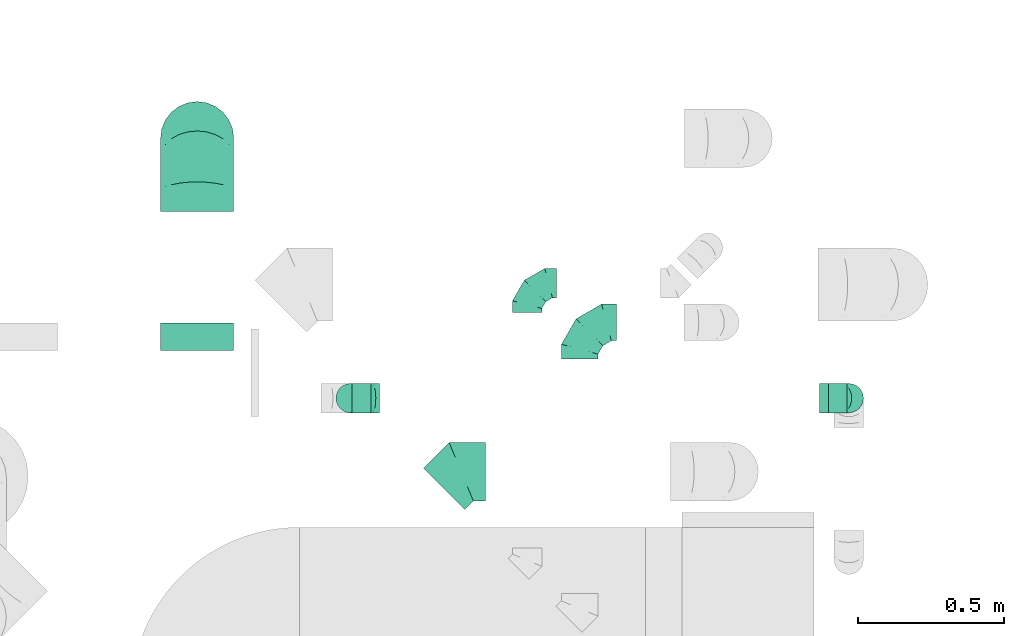
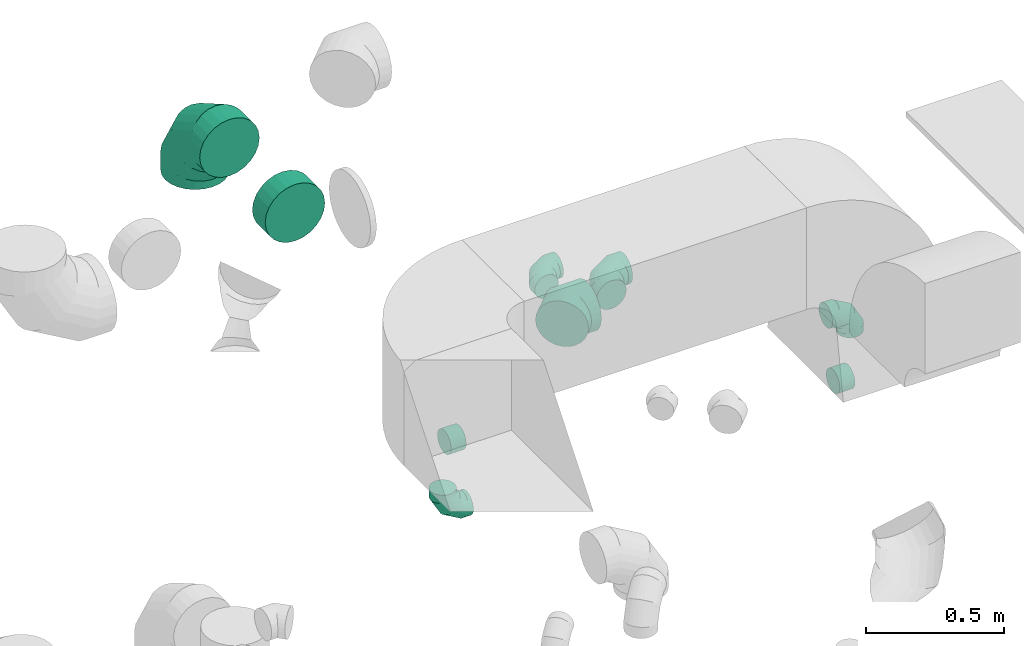
# One storey, part 38 of 59: 9 flow fittings.
"""IFC2X3 building model written with IfcOpenShell, lengths in millimetres."""

from ifc_helpers import new_model, entity, si_unit, converted_unit, derived_unit, direction, frame, origin, place, context, subcontext, project, spatial, faceted_brep, source, transform, mapped, material, type_object, type_shapes, element, save


model = new_model("IFC2X3")

# Units and contexts
model_context = context("Model", 3, precision=0.01, world=origin(), true_north=direction((6.12303176911189e-17, 1.0)))
body_context = subcontext(model_context, "Body", "Model", "MODEL_VIEW")
ifc_project = project(units=[si_unit("LENGTHUNIT", "METRE", prefix="MILLI"), si_unit("AREAUNIT", "SQUARE_METRE"), si_unit("VOLUMEUNIT", "CUBIC_METRE"), converted_unit("PLANEANGLEUNIT", "DEGREE", entity("IfcRatioMeasure", 0.0174532925199433), si_unit("PLANEANGLEUNIT", "RADIAN"), dimensions=[0, 0, 0, 0, 0, 0, 0]), si_unit("MASSUNIT", "GRAM", prefix="KILO"), derived_unit("MASSDENSITYUNIT", [(si_unit("MASSUNIT", "GRAM", prefix="KILO"), 1), (si_unit("LENGTHUNIT", "METRE"), -3)]), derived_unit("MOMENTOFINERTIAUNIT", [(si_unit("LENGTHUNIT", "METRE"), 4)]), si_unit("TIMEUNIT", "SECOND"), si_unit("FREQUENCYUNIT", "HERTZ"), si_unit("THERMODYNAMICTEMPERATUREUNIT", "DEGREE_CELSIUS"), derived_unit("THERMALTRANSMITTANCEUNIT", [(si_unit("MASSUNIT", "GRAM", prefix="KILO"), 1), (si_unit("THERMODYNAMICTEMPERATUREUNIT", "KELVIN"), -1), (si_unit("TIMEUNIT", "SECOND"), -3)]), derived_unit("VOLUMETRICFLOWRATEUNIT", [(si_unit("LENGTHUNIT", "METRE"), 3), (si_unit("TIMEUNIT", "SECOND"), -1)]), derived_unit("MASSFLOWRATEUNIT", [(si_unit("MASSUNIT", "GRAM", prefix="KILO"), 1), (si_unit("TIMEUNIT", "SECOND"), -1)]), derived_unit("ROTATIONALFREQUENCYUNIT", [(si_unit("TIMEUNIT", "SECOND"), -1)]), si_unit("ELECTRICCURRENTUNIT", "AMPERE"), si_unit("ELECTRICVOLTAGEUNIT", "VOLT"), si_unit("POWERUNIT", "WATT"), si_unit("FORCEUNIT", "NEWTON", prefix="KILO"), si_unit("ILLUMINANCEUNIT", "LUX"), si_unit("LUMINOUSFLUXUNIT", "LUMEN"), si_unit("LUMINOUSINTENSITYUNIT", "CANDELA"), derived_unit("USERDEFINED", [(si_unit("MASSUNIT", "GRAM", prefix="KILO"), -1), (si_unit("LENGTHUNIT", "METRE"), -2), (si_unit("TIMEUNIT", "SECOND"), 3), (si_unit("LUMINOUSFLUXUNIT", "LUMEN"), 1)]), derived_unit("LINEARVELOCITYUNIT", [(si_unit("LENGTHUNIT", "METRE"), 1), (si_unit("TIMEUNIT", "SECOND"), -1)]), si_unit("PRESSUREUNIT", "PASCAL"), derived_unit("USERDEFINED", [(si_unit("LENGTHUNIT", "METRE"), -2), (si_unit("MASSUNIT", "GRAM", prefix="KILO"), 1), (si_unit("TIMEUNIT", "SECOND"), -2)]), derived_unit("LINEARFORCEUNIT", [(si_unit("MASSUNIT", "GRAM", prefix="KILO"), 1), (si_unit("LENGTHUNIT", "METRE"), 1), (si_unit("TIMEUNIT", "SECOND"), -2), (si_unit("LENGTHUNIT", "METRE"), -1)]), derived_unit("PLANARFORCEUNIT", [(si_unit("MASSUNIT", "GRAM", prefix="KILO"), 1), (si_unit("LENGTHUNIT", "METRE"), 1), (si_unit("TIMEUNIT", "SECOND"), -2), (si_unit("LENGTHUNIT", "METRE"), -2)])], contexts=[model_context])

# Site, building, storey
site_placement = place(None, origin())
site = spatial("IfcSite", under=ifc_project, at=site_placement, CompositionType="ELEMENT")
building_placement = place(site_placement, origin())
building = spatial("IfcBuilding", under=site, at=building_placement, CompositionType="ELEMENT")
storey_placement = place(building_placement, frame((0.0, 0.0, 28200.0)))
storey = spatial("IfcBuildingStorey", under=building, at=storey_placement, CompositionType="ELEMENT", Elevation=28200.0)

# Flow fittings
ifc_material = material()
duct_fitting_type_1 = type_object("IfcDuctFittingType", PredefinedType="NOTDEFINED", material=ifc_material)
shared_shape_1 = source(origin(), body_context, "Body", "Brep", [
    faceted_brep([(-100.0, 0.0, -50.0), (-100.0, -12.94, -48.3), (-100.0, -25.0, -43.3), (-100.0, -35.36, -35.36), (-100.0, -43.3, -25.0), (-100.0, -48.3, -12.94), (-100.0, -50.0, 0.0), (-100.0, -48.3, 12.94), (-100.0, -43.3, 25.0), (-100.0, -35.36, 35.36), (-100.0, -25.0, 43.3), (-100.0, -12.94, 48.3), (-100.0, 0.0, 50.0), (-100.0, 12.94, 48.3), (-100.0, 25.0, 43.3), (-100.0, 35.36, 35.36), (-100.0, 43.3, 25.0), (-100.0, 48.3, 12.94), (-100.0, 50.0, 0.0), (-100.0, 48.3, -12.94), (-100.0, 43.3, -25.0), (-100.0, 35.36, -35.36), (-100.0, 25.0, -43.3), (-100.0, 12.94, -48.3), (-76.67, 12.94, 48.3), (-79.9, 25.0, 43.3), (-73.21, 0.0, 50.0), (-82.68, 35.36, 35.36), (-86.15, 48.3, 12.94), (-86.6, 50.0, 0.0), (-84.81, 43.3, 25.0), (-84.81, 43.3, -25.0), (-82.68, 35.36, -35.36), (-86.15, 48.3, -12.94), (-76.67, 12.94, -48.3), (-73.21, 0.0, -50.0), (-79.9, 25.0, -43.3), (-69.74, -12.94, -48.3), (-66.51, -25.0, -43.3), (-63.73, -35.36, -35.36), (-61.6, -43.3, -25.0), (-60.26, -48.3, -12.94), (-59.81, -50.0, 0.0), (-60.26, -48.3, 12.94), (-61.6, -43.3, 25.0), (-63.73, -35.36, 35.36), (-66.51, -25.0, 43.3), (-69.74, -12.94, 48.3), (-36.27, 36.27, 48.3), (-45.1, 45.1, 43.3), (-26.79, 26.79, 50.0), (-52.68, 52.68, 35.36), (-58.49, 58.49, 25.0), (-62.15, 62.15, 12.94), (-63.4, 63.4, 0.0), (-62.15, 62.15, -12.94), (-58.49, 58.49, -25.0), (-52.68, 52.68, -35.36), (-36.27, 36.27, -48.3), (-26.79, 26.79, -50.0), (-45.1, 45.1, -43.3), (-17.32, 17.32, -48.3), (-8.49, 8.49, -43.3), (-0.91, 0.91, -35.36), (4.9, -4.9, -25.0), (8.56, -8.56, -12.94), (9.81, -9.81, 0.0), (8.56, -8.56, 12.94), (4.9, -4.9, 25.0), (-0.91, 0.91, 35.36), (-8.49, 8.49, 43.3), (-17.32, 17.32, 48.3), (-12.94, 76.67, 48.3), (-25.0, 79.9, 43.3), (0.0, 73.21, 50.0), (-35.36, 82.68, 35.36), (-43.3, 84.81, 25.0), (-48.3, 86.15, 12.94), (-50.0, 86.6, 0.0), (-48.3, 86.15, -12.94), (-43.3, 84.81, -25.0), (-35.36, 82.68, -35.36), (-12.94, 76.67, -48.3), (0.0, 73.21, -50.0), (-25.0, 79.9, -43.3), (12.94, 69.74, -48.3), (25.0, 66.51, -43.3), (35.36, 63.73, -35.36), (43.3, 61.6, -25.0), (48.3, 60.26, -12.94), (50.0, 59.81, 0.0), (48.3, 60.26, 12.94), (43.3, 61.6, 25.0), (35.36, 63.73, 35.36), (25.0, 66.51, 43.3), (12.94, 69.74, 48.3), (-12.94, 100.0, -48.3), (-25.0, 100.0, -43.3), (-35.36, 100.0, -35.36), (-43.3, 100.0, -25.0), (-48.3, 100.0, -12.94), (-50.0, 100.0, 0.0), (-48.3, 100.0, 12.94), (-43.3, 100.0, 25.0), (-35.36, 100.0, 35.36), (-25.0, 100.0, 43.3), (-12.94, 100.0, 48.3), (0.0, 100.0, 50.0), (12.94, 100.0, 48.3), (25.0, 100.0, 43.3), (35.36, 100.0, 35.36), (43.3, 100.0, 25.0), (48.3, 100.0, 12.94), (50.0, 100.0, 0.0), (48.3, 100.0, -12.94), (43.3, 100.0, -25.0), (35.36, 100.0, -35.36), (25.0, 100.0, -43.3), (12.94, 100.0, -48.3), (0.0, 100.0, -50.0)], [[[0, 1, 2, 3, 4, 5, 6, 7, 8, 9, 10, 11, 12, 13, 14, 15, 16, 17, 18, 19, 20, 21, 22, 23]], [[24, 25, 14, 13]], [[26, 24, 13, 12]], [[14, 25, 27, 15]], [[28, 29, 18, 17]], [[30, 28, 17, 16]], [[15, 27, 30, 16]], [[20, 31, 32, 21]], [[33, 31, 20, 19]], [[18, 29, 33, 19]], [[34, 35, 0, 23]], [[36, 34, 23, 22]], [[32, 36, 22, 21]], [[2, 1, 37, 38]], [[3, 2, 38, 39]], [[0, 35, 37, 1]], [[5, 4, 40, 41]], [[6, 5, 41, 42]], [[3, 39, 40, 4]], [[6, 42, 43, 7]], [[7, 43, 44, 8]], [[8, 44, 45, 9]], [[10, 46, 47, 11]], [[11, 47, 26, 12]], [[10, 9, 45, 46]], [[48, 49, 25, 24]], [[50, 48, 24, 26]], [[27, 25, 49, 51]], [[52, 53, 28, 30]], [[51, 52, 30, 27]], [[29, 28, 53, 54]], [[55, 56, 31, 33]], [[54, 55, 33, 29]], [[57, 32, 31, 56]], [[58, 59, 35, 34]], [[60, 58, 34, 36]], [[57, 60, 36, 32]], [[37, 35, 59, 61]], [[38, 37, 61, 62]], [[39, 38, 62, 63]], [[41, 40, 64, 65]], [[42, 41, 65, 66]], [[63, 64, 40, 39]], [[43, 42, 66, 67]], [[44, 43, 67, 68]], [[68, 69, 45, 44]], [[46, 45, 69, 70]], [[47, 46, 70, 71]], [[26, 47, 71, 50]], [[72, 73, 49, 48]], [[74, 72, 48, 50]], [[51, 49, 73, 75]], [[76, 77, 53, 52]], [[75, 76, 52, 51]], [[54, 53, 77, 78]], [[79, 80, 56, 55]], [[78, 79, 55, 54]], [[81, 57, 56, 80]], [[82, 83, 59, 58]], [[84, 82, 58, 60]], [[81, 84, 60, 57]], [[61, 59, 83, 85]], [[62, 61, 85, 86]], [[63, 62, 86, 87]], [[65, 64, 88, 89]], [[66, 65, 89, 90]], [[87, 88, 64, 63]], [[67, 66, 90, 91]], [[68, 67, 91, 92]], [[92, 93, 69, 68]], [[70, 69, 93, 94]], [[71, 70, 94, 95]], [[50, 71, 95, 74]], [[96, 97, 98, 99, 100, 101, 102, 103, 104, 105, 106, 107, 108, 109, 110, 111, 112, 113, 114, 115, 116, 117, 118, 119]], [[72, 74, 107, 106]], [[73, 72, 106, 105]], [[75, 73, 105, 104]], [[77, 76, 103, 102]], [[78, 77, 102, 101]], [[75, 104, 103, 76]], [[78, 101, 100, 79]], [[79, 100, 99, 80]], [[80, 99, 98, 81]], [[96, 119, 83, 82]], [[97, 96, 82, 84]], [[84, 81, 98, 97]], [[83, 119, 118, 85]], [[85, 118, 117, 86]], [[86, 117, 116, 87]], [[88, 115, 114, 89]], [[89, 114, 113, 90]], [[87, 116, 115, 88]], [[91, 90, 113, 112]], [[92, 91, 112, 111]], [[93, 92, 111, 110]], [[95, 94, 109, 108]], [[74, 95, 108, 107]], [[110, 109, 94, 93]]]),
])
type_shapes(duct_fitting_type_1, [shared_shape_1])
for number, where, z_axis, x_axis in (
    (1, (57621.5, 12105.64, 1700.0), (0.0, -1.0, 0.0), (0.0, 0.0, -1.0)),
    (2, (59324.53, 12105.64, 2000.42), (0.0, -1.0, 0.0), (0.0, 0.0, 1.0)),
    (3, (58225.44, 12498.5, 2300.0), (0.0, 0.0, 1.0), (-1.0, 0.0, 0.0)),
):
    element("IfcFlowFitting", number, at=place(storey_placement, frame(where, z_axis=z_axis, x_axis=x_axis)), inside=storey, type_object=duct_fitting_type_1, material=ifc_material, context=body_context, shape_type="MappedRepresentation", body=[
        mapped(shared_shape_1, transform((0.0, 0.0, 0.0), scale=1.0)),
    ])
duct_fitting_type_2 = type_object("IfcDuctFittingType", PredefinedType="NOTDEFINED", material=ifc_material)
shared_shape_2 = source(origin(), body_context, "Body", "Brep", [
    faceted_brep([(-250.0, 0.0, -125.0), (-250.0, -32.35, -120.74), (-250.0, -62.5, -108.25), (-250.0, -88.39, -88.39), (-250.0, -108.25, -62.5), (-250.0, -120.74, -32.35), (-250.0, -125.0, 0.0), (-250.0, -120.74, 32.35), (-250.0, -108.25, 62.5), (-250.0, -88.39, 88.39), (-250.0, -62.5, 108.25), (-250.0, -32.35, 120.74), (-250.0, 0.0, 125.0), (-250.0, 32.35, 120.74), (-250.0, 62.5, 108.25), (-250.0, 88.39, 88.39), (-250.0, 108.25, 62.5), (-250.0, 120.74, 32.35), (-250.0, 125.0, 0.0), (-250.0, 120.74, -32.35), (-250.0, 108.25, -62.5), (-250.0, 88.39, -88.39), (-250.0, 62.5, -108.25), (-250.0, 32.35, -120.74), (-191.68, 32.35, 120.74), (-199.76, 62.5, 108.25), (-183.01, 0.0, 125.0), (-206.7, 88.39, 88.39), (-215.37, 120.74, 32.35), (-216.51, 125.0, 0.0), (-212.02, 108.25, 62.5), (-212.02, 108.25, -62.5), (-206.7, 88.39, -88.39), (-215.37, 120.74, -32.35), (-191.68, 32.35, -120.74), (-183.01, 0.0, -125.0), (-199.76, 62.5, -108.25), (-174.34, -32.35, -120.74), (-166.27, -62.5, -108.25), (-159.33, -88.39, -88.39), (-154.01, -108.25, -62.5), (-150.66, -120.74, -32.35), (-149.52, -125.0, 0.0), (-150.66, -120.74, 32.35), (-154.01, -108.25, 62.5), (-159.33, -88.39, 88.39), (-166.27, -62.5, 108.25), (-174.34, -32.35, 120.74), (-90.67, 90.67, 120.74), (-112.74, 112.74, 108.25), (-66.99, 66.99, 125.0), (-131.69, 131.69, 88.39), (-146.23, 146.23, 62.5), (-155.38, 155.38, 32.35), (-158.49, 158.49, 0.0), (-155.38, 155.38, -32.35), (-146.23, 146.23, -62.5), (-131.69, 131.69, -88.39), (-90.67, 90.67, -120.74), (-66.99, 66.99, -125.0), (-112.74, 112.74, -108.25), (-43.3, 43.3, -120.74), (-21.23, 21.23, -108.25), (-2.28, 2.28, -88.39), (12.26, -12.26, -62.5), (21.4, -21.4, -32.35), (24.52, -24.52, 0.0), (21.4, -21.4, 32.35), (12.26, -12.26, 62.5), (-2.28, 2.28, 88.39), (-21.23, 21.23, 108.25), (-43.3, 43.3, 120.74), (-32.35, 191.68, 120.74), (-62.5, 199.76, 108.25), (0.0, 183.01, 125.0), (-88.39, 206.7, 88.39), (-108.25, 212.02, 62.5), (-120.74, 215.37, 32.35), (-125.0, 216.51, 0.0), (-120.74, 215.37, -32.35), (-108.25, 212.02, -62.5), (-88.39, 206.7, -88.39), (-32.35, 191.68, -120.74), (0.0, 183.01, -125.0), (-62.5, 199.76, -108.25), (32.35, 174.34, -120.74), (62.5, 166.27, -108.25), (88.39, 159.33, -88.39), (108.25, 154.01, -62.5), (120.74, 150.66, -32.35), (125.0, 149.52, 0.0), (120.74, 150.66, 32.35), (108.25, 154.01, 62.5), (88.39, 159.33, 88.39), (62.5, 166.27, 108.25), (32.35, 174.34, 120.74), (-32.35, 250.0, -120.74), (-62.5, 250.0, -108.25), (-88.39, 250.0, -88.39), (-108.25, 250.0, -62.5), (-120.74, 250.0, -32.35), (-125.0, 250.0, 0.0), (-120.74, 250.0, 32.35), (-108.25, 250.0, 62.5), (-88.39, 250.0, 88.39), (-62.5, 250.0, 108.25), (-32.35, 250.0, 120.74), (0.0, 250.0, 125.0), (32.35, 250.0, 120.74), (62.5, 250.0, 108.25), (88.39, 250.0, 88.39), (108.25, 250.0, 62.5), (120.74, 250.0, 32.35), (125.0, 250.0, 0.0), (120.74, 250.0, -32.35), (108.25, 250.0, -62.5), (88.39, 250.0, -88.39), (62.5, 250.0, -108.25), (32.35, 250.0, -120.74), (0.0, 250.0, -125.0)], [[[0, 1, 2, 3, 4, 5, 6, 7, 8, 9, 10, 11, 12, 13, 14, 15, 16, 17, 18, 19, 20, 21, 22, 23]], [[24, 25, 14, 13]], [[26, 24, 13, 12]], [[14, 25, 27, 15]], [[28, 29, 18, 17]], [[30, 28, 17, 16]], [[15, 27, 30, 16]], [[20, 31, 32, 21]], [[33, 31, 20, 19]], [[18, 29, 33, 19]], [[34, 35, 0, 23]], [[36, 34, 23, 22]], [[21, 32, 36, 22]], [[1, 0, 35, 37]], [[2, 1, 37, 38]], [[38, 39, 3, 2]], [[5, 4, 40, 41]], [[6, 5, 41, 42]], [[39, 40, 4, 3]], [[6, 42, 43, 7]], [[7, 43, 44, 8]], [[8, 44, 45, 9]], [[9, 45, 46, 10]], [[10, 46, 47, 11]], [[26, 12, 11, 47]], [[48, 49, 25, 24]], [[50, 48, 24, 26]], [[27, 25, 49, 51]], [[52, 53, 28, 30]], [[51, 52, 30, 27]], [[29, 28, 53, 54]], [[55, 56, 31, 33]], [[54, 55, 33, 29]], [[32, 31, 56, 57]], [[58, 59, 35, 34]], [[60, 58, 34, 36]], [[57, 60, 36, 32]], [[37, 35, 59, 61]], [[38, 37, 61, 62]], [[39, 38, 62, 63]], [[41, 40, 64, 65]], [[42, 41, 65, 66]], [[63, 64, 40, 39]], [[43, 42, 66, 67]], [[44, 43, 67, 68]], [[68, 69, 45, 44]], [[46, 45, 69, 70]], [[47, 46, 70, 71]], [[26, 47, 71, 50]], [[72, 73, 49, 48]], [[74, 72, 48, 50]], [[51, 49, 73, 75]], [[76, 77, 53, 52]], [[75, 76, 52, 51]], [[54, 53, 77, 78]], [[79, 80, 56, 55]], [[78, 79, 55, 54]], [[57, 56, 80, 81]], [[82, 83, 59, 58]], [[84, 82, 58, 60]], [[81, 84, 60, 57]], [[61, 59, 83, 85]], [[62, 61, 85, 86]], [[63, 62, 86, 87]], [[65, 64, 88, 89]], [[66, 65, 89, 90]], [[87, 88, 64, 63]], [[67, 66, 90, 91]], [[68, 67, 91, 92]], [[92, 93, 69, 68]], [[70, 69, 93, 94]], [[71, 70, 94, 95]], [[50, 71, 95, 74]], [[96, 97, 98, 99, 100, 101, 102, 103, 104, 105, 106, 107, 108, 109, 110, 111, 112, 113, 114, 115, 116, 117, 118, 119]], [[72, 74, 107, 106]], [[73, 72, 106, 105]], [[75, 73, 105, 104]], [[77, 76, 103, 102]], [[78, 77, 102, 101]], [[75, 104, 103, 76]], [[78, 101, 100, 79]], [[79, 100, 99, 80]], [[80, 99, 98, 81]], [[84, 97, 96, 82]], [[82, 96, 119, 83]], [[84, 81, 98, 97]], [[83, 119, 118, 85]], [[85, 118, 117, 86]], [[116, 87, 86, 117]], [[88, 115, 114, 89]], [[89, 114, 113, 90]], [[115, 88, 87, 116]], [[91, 90, 113, 112]], [[92, 91, 112, 111]], [[111, 110, 93, 92]], [[95, 94, 109, 108]], [[74, 95, 108, 107]], [[110, 109, 94, 93]]]),
])
type_shapes(duct_fitting_type_2, [shared_shape_2])
flow_fitting_1_placement = place(storey_placement, frame((57097.66, 12994.01, 3100.0), z_axis=(1.0, 0.0, 0.0), x_axis=(0.0, 0.0, 1.0)))
element("IfcFlowFitting", 4, at=flow_fitting_1_placement, inside=storey, type_object=duct_fitting_type_2, material=ifc_material, context=body_context, shape_type="MappedRepresentation", body=[
    mapped(shared_shape_2, transform((0.0, 0.0, 0.0), scale=1.0)),
])
duct_fitting_type_3 = type_object("IfcDuctFittingType", PredefinedType="NOTDEFINED", material=ifc_material)
shared_shape_3 = source(origin(), body_context, "Body", "Brep", [
    faceted_brep([(-125.0, 0.0, -62.5), (-125.0, -16.18, -60.37), (-125.0, -31.25, -54.13), (-125.0, -44.19, -44.19), (-125.0, -54.13, -31.25), (-125.0, -60.37, -16.18), (-125.0, -62.5, 0.0), (-125.0, -60.37, 16.18), (-125.0, -54.13, 31.25), (-125.0, -44.19, 44.19), (-125.0, -31.25, 54.13), (-125.0, -16.18, 60.37), (-125.0, 0.0, 62.5), (-125.0, 16.18, 60.37), (-125.0, 31.25, 54.13), (-125.0, 44.19, 44.19), (-125.0, 54.13, 31.25), (-125.0, 60.37, 16.18), (-125.0, 62.5, 0.0), (-125.0, 60.37, -16.18), (-125.0, 54.13, -31.25), (-125.0, 44.19, -44.19), (-125.0, 31.25, -54.13), (-125.0, 16.18, -60.37), (-95.84, 16.18, 60.37), (-99.88, 31.25, 54.13), (-91.51, 0.0, 62.5), (-103.35, 44.19, 44.19), (-107.68, 60.37, 16.18), (-108.25, 62.5, 0.0), (-106.01, 54.13, 31.25), (-106.01, 54.13, -31.25), (-103.35, 44.19, -44.19), (-107.68, 60.37, -16.18), (-95.84, 16.18, -60.37), (-91.51, 0.0, -62.5), (-99.88, 31.25, -54.13), (-87.17, -16.18, -60.37), (-83.13, -31.25, -54.13), (-79.66, -44.19, -44.19), (-77.0, -54.13, -31.25), (-75.33, -60.37, -16.18), (-74.76, -62.5, 0.0), (-75.33, -60.37, 16.18), (-77.0, -54.13, 31.25), (-79.66, -44.19, 44.19), (-83.13, -31.25, 54.13), (-87.17, -16.18, 60.37), (-45.34, 45.34, 60.37), (-56.37, 56.37, 54.13), (-33.49, 33.49, 62.5), (-65.85, 65.85, 44.19), (-73.12, 73.12, 31.25), (-77.69, 77.69, 16.18), (-79.25, 79.25, 0.0), (-77.69, 77.69, -16.18), (-73.12, 73.12, -31.25), (-65.85, 65.85, -44.19), (-45.34, 45.34, -60.37), (-33.49, 33.49, -62.5), (-56.37, 56.37, -54.13), (-21.65, 21.65, -60.37), (-10.62, 10.62, -54.13), (-1.14, 1.14, -44.19), (6.13, -6.13, -31.25), (10.7, -10.7, -16.18), (12.26, -12.26, 0.0), (10.7, -10.7, 16.18), (6.13, -6.13, 31.25), (-1.14, 1.14, 44.19), (-10.62, 10.62, 54.13), (-21.65, 21.65, 60.37), (-16.18, 95.84, 60.37), (-31.25, 99.88, 54.13), (0.0, 91.51, 62.5), (-44.19, 103.35, 44.19), (-54.13, 106.01, 31.25), (-60.37, 107.68, 16.18), (-62.5, 108.25, 0.0), (-60.37, 107.68, -16.18), (-54.13, 106.01, -31.25), (-44.19, 103.35, -44.19), (-16.18, 95.84, -60.37), (0.0, 91.51, -62.5), (-31.25, 99.88, -54.13), (16.18, 87.17, -60.37), (31.25, 83.13, -54.13), (44.19, 79.66, -44.19), (54.13, 77.0, -31.25), (60.37, 75.33, -16.18), (62.5, 74.76, 0.0), (60.37, 75.33, 16.18), (54.13, 77.0, 31.25), (44.19, 79.66, 44.19), (31.25, 83.13, 54.13), (16.18, 87.17, 60.37), (-16.18, 125.0, -60.37), (-31.25, 125.0, -54.13), (-44.19, 125.0, -44.19), (-54.13, 125.0, -31.25), (-60.37, 125.0, -16.18), (-62.5, 125.0, 0.0), (-60.37, 125.0, 16.18), (-54.13, 125.0, 31.25), (-44.19, 125.0, 44.19), (-31.25, 125.0, 54.13), (-16.18, 125.0, 60.37), (0.0, 125.0, 62.5), (16.18, 125.0, 60.37), (31.25, 125.0, 54.13), (44.19, 125.0, 44.19), (54.13, 125.0, 31.25), (60.37, 125.0, 16.18), (62.5, 125.0, 0.0), (60.37, 125.0, -16.18), (54.13, 125.0, -31.25), (44.19, 125.0, -44.19), (31.25, 125.0, -54.13), (16.18, 125.0, -60.37), (0.0, 125.0, -62.5)], [[[0, 1, 2, 3, 4, 5, 6, 7, 8, 9, 10, 11, 12, 13, 14, 15, 16, 17, 18, 19, 20, 21, 22, 23]], [[24, 25, 14, 13]], [[26, 24, 13, 12]], [[14, 25, 27, 15]], [[28, 29, 18, 17]], [[30, 28, 17, 16]], [[15, 27, 30, 16]], [[20, 31, 32, 21]], [[33, 31, 20, 19]], [[18, 29, 33, 19]], [[34, 35, 0, 23]], [[36, 34, 23, 22]], [[21, 32, 36, 22]], [[1, 0, 35, 37]], [[2, 1, 37, 38]], [[38, 39, 3, 2]], [[5, 4, 40, 41]], [[6, 5, 41, 42]], [[39, 40, 4, 3]], [[6, 42, 43, 7]], [[7, 43, 44, 8]], [[45, 9, 8, 44]], [[9, 45, 46, 10]], [[10, 46, 47, 11]], [[26, 12, 11, 47]], [[48, 49, 25, 24]], [[50, 48, 24, 26]], [[27, 25, 49, 51]], [[52, 53, 28, 30]], [[51, 52, 30, 27]], [[29, 28, 53, 54]], [[55, 56, 31, 33]], [[54, 55, 33, 29]], [[57, 32, 31, 56]], [[58, 59, 35, 34]], [[60, 58, 34, 36]], [[57, 60, 36, 32]], [[37, 35, 59, 61]], [[38, 37, 61, 62]], [[39, 38, 62, 63]], [[41, 40, 64, 65]], [[42, 41, 65, 66]], [[63, 64, 40, 39]], [[43, 42, 66, 67]], [[44, 43, 67, 68]], [[68, 69, 45, 44]], [[46, 45, 69, 70]], [[47, 46, 70, 71]], [[26, 47, 71, 50]], [[72, 73, 49, 48]], [[74, 72, 48, 50]], [[51, 49, 73, 75]], [[76, 77, 53, 52]], [[75, 76, 52, 51]], [[54, 53, 77, 78]], [[79, 80, 56, 55]], [[78, 79, 55, 54]], [[81, 57, 56, 80]], [[82, 83, 59, 58]], [[84, 82, 58, 60]], [[81, 84, 60, 57]], [[61, 59, 83, 85]], [[62, 61, 85, 86]], [[63, 62, 86, 87]], [[65, 64, 88, 89]], [[66, 65, 89, 90]], [[87, 88, 64, 63]], [[67, 66, 90, 91]], [[68, 67, 91, 92]], [[92, 93, 69, 68]], [[70, 69, 93, 94]], [[71, 70, 94, 95]], [[50, 71, 95, 74]], [[96, 97, 98, 99, 100, 101, 102, 103, 104, 105, 106, 107, 108, 109, 110, 111, 112, 113, 114, 115, 116, 117, 118, 119]], [[72, 74, 107, 106]], [[73, 72, 106, 105]], [[75, 73, 105, 104]], [[77, 76, 103, 102]], [[78, 77, 102, 101]], [[75, 104, 103, 76]], [[78, 101, 100, 79]], [[79, 100, 99, 80]], [[80, 99, 98, 81]], [[96, 119, 83, 82]], [[97, 96, 82, 84]], [[84, 81, 98, 97]], [[83, 119, 118, 85]], [[85, 118, 117, 86]], [[116, 87, 86, 117]], [[88, 115, 114, 89]], [[89, 114, 113, 90]], [[115, 88, 87, 116]], [[91, 90, 113, 112]], [[92, 91, 112, 111]], [[111, 110, 93, 92]], [[95, 94, 109, 108]], [[74, 95, 108, 107]], [[110, 109, 94, 93]]]),
])
type_shapes(duct_fitting_type_3, [shared_shape_3])
flow_fitting_2_placement = place(storey_placement, frame((58405.03, 12364.32, 2297.5), z_axis=(0.0, 0.0, 1.0), x_axis=(-1.0, 0.0, 0.0)))
element("IfcFlowFitting", 5, at=flow_fitting_2_placement, inside=storey, type_object=duct_fitting_type_3, material=ifc_material, context=body_context, shape_type="MappedRepresentation", body=[
    mapped(shared_shape_3, transform((0.0, 0.0, 0.0), scale=1.0)),
])
duct_fitting_type_4 = type_object("IfcDuctFittingType", PredefinedType="NOTDEFINED", material=ifc_material)
shared_shape_4 = source(origin(), body_context, "Body", "Brep", [
    faceted_brep([(20.0, 12.94, -48.3), (20.0, 25.0, -43.3), (20.0, 35.36, -35.36), (20.0, 43.3, -25.0), (20.0, 48.3, -12.94), (20.0, 50.0, 0.0), (20.0, 48.3, 12.94), (20.0, 43.3, 25.0), (20.0, 35.36, 35.36), (20.0, 25.0, 43.3), (20.0, 12.94, 48.3), (20.0, 0.0, 50.0), (20.0, -12.94, 48.3), (20.0, -25.0, 43.3), (20.0, -35.36, 35.36), (20.0, -43.3, 25.0), (20.0, -48.3, 12.94), (20.0, -50.0, 0.0), (20.0, -48.3, -12.94), (20.0, -43.3, -25.0), (20.0, -35.36, -35.36), (20.0, -25.0, -43.3), (20.0, -12.94, -48.3), (20.0, 0.0, -50.0), (0.0, 0.0, 50.0), (0.0, 12.94, 48.3), (-43.9, 12.94, 48.3), (-43.9, 0.0, 50.0), (0.0, 25.0, 43.3), (-43.9, 25.0, 43.3), (0.0, 35.36, 35.36), (-43.9, 35.36, 35.36), (0.0, 43.3, 25.0), (0.0, 48.3, 12.94), (-43.9, 48.3, 12.94), (-43.9, 43.3, 25.0), (0.0, 50.0, 0.0), (-43.9, 50.0, 0.0), (0.0, 48.3, -12.94), (-43.9, 48.3, -12.94), (0.0, 43.3, -25.0), (-43.9, 43.3, -25.0), (0.0, 35.36, -35.36), (-43.9, 35.36, -35.36), (0.0, 25.0, -43.3), (0.0, 12.94, -48.3), (-43.9, 12.94, -48.3), (-43.9, 25.0, -43.3), (0.0, 0.0, -50.0), (-43.9, 0.0, -50.0), (0.0, -12.94, -48.3), (-43.9, -12.94, -48.3), (0.0, -25.0, -43.3), (-43.9, -25.0, -43.3), (0.0, -35.36, -35.36), (-43.9, -35.36, -35.36), (0.0, -43.3, -25.0), (0.0, -48.3, -12.94), (-43.9, -48.3, -12.94), (-43.9, -43.3, -25.0), (0.0, -50.0, 0.0), (-43.9, -50.0, 0.0), (0.0, -48.3, 12.94), (-43.9, -48.3, 12.94), (0.0, -43.3, 25.0), (-43.9, -43.3, 25.0), (0.0, -35.36, 35.36), (-43.9, -35.36, 35.36), (0.0, -25.0, 43.3), (0.0, -12.94, 48.3), (-43.9, -12.94, 48.3), (-43.9, -25.0, 43.3)], [[[0, 1, 2, 3, 4, 5, 6, 7, 8, 9, 10, 11, 12, 13, 14, 15, 16, 17, 18, 19, 20, 21, 22, 23]], [[24, 11, 10, 25, 26, 27]], [[25, 10, 9, 28, 29, 26]], [[28, 9, 8, 30, 31, 29]], [[32, 7, 6, 33, 34, 35]], [[33, 6, 5, 36, 37, 34]], [[30, 8, 7, 32, 35, 31]], [[36, 5, 4, 38, 39, 37]], [[38, 4, 3, 40, 41, 39]], [[40, 3, 2, 42, 43, 41]], [[44, 1, 0, 45, 46, 47]], [[45, 0, 23, 48, 49, 46]], [[42, 2, 1, 44, 47, 43]], [[48, 23, 22, 50, 51, 49]], [[50, 22, 21, 52, 53, 51]], [[52, 21, 20, 54, 55, 53]], [[56, 19, 18, 57, 58, 59]], [[57, 18, 17, 60, 61, 58]], [[54, 20, 19, 56, 59, 55]], [[60, 17, 16, 62, 63, 61]], [[62, 16, 15, 64, 65, 63]], [[64, 15, 14, 66, 67, 65]], [[68, 13, 12, 69, 70, 71]], [[69, 12, 11, 24, 27, 70]], [[66, 14, 13, 68, 71, 67]], [[49, 51, 53, 55, 59, 58, 61, 63, 65, 67, 71, 70, 27, 26, 29, 31, 35, 34, 37, 39, 41, 43, 47, 46]]]),
])
type_shapes(duct_fitting_type_4, [shared_shape_4])
for number, where, z_axis, x_axis in (
    (6, (59274.53, 12105.64, 1700.0), (0.0, 1.0, 0.0), (-1.0, 0.0, 0.0)),
    (7, (57671.5, 12105.64, 2000.42), (0.0, -1.0, 0.0), (1.0, 0.0, 0.0)),
):
    element("IfcFlowFitting", number, at=place(storey_placement, frame(where, z_axis=z_axis, x_axis=x_axis)), inside=storey, type_object=duct_fitting_type_4, material=ifc_material, context=body_context, shape_type="MappedRepresentation", body=[
        mapped(shared_shape_4, transform((0.0, 0.0, 0.0), scale=1.0)),
    ])
duct_fitting_type_5 = type_object("IfcDuctFittingType", PredefinedType="NOTDEFINED", material=ifc_material)
shared_shape_5 = source(origin(), body_context, "Body", "Brep", [
    faceted_brep([(-82.84, 0.0, -100.0), (-82.84, -25.88, -96.59), (-82.84, -50.0, -86.6), (-82.84, -70.71, -70.71), (-82.84, -86.6, -50.0), (-82.84, -96.59, -25.88), (-82.84, -100.0, 0.0), (-82.84, -96.59, 25.88), (-82.84, -86.6, 50.0), (-82.84, -70.71, 70.71), (-82.84, -50.0, 86.6), (-82.84, -25.88, 96.59), (-82.84, 0.0, 100.0), (-82.84, 25.88, 96.59), (-82.84, 50.0, 86.6), (-82.84, 70.71, 70.71), (-82.84, 86.6, 50.0), (-82.84, 96.59, 25.88), (-82.84, 100.0, 0.0), (-82.84, 96.59, -25.88), (-82.84, 86.6, -50.0), (-82.84, 70.71, -70.71), (-82.84, 50.0, -86.6), (-82.84, 25.88, -96.59), (-10.72, 25.88, 96.59), (-20.71, 50.0, 86.6), (0.0, 0.0, 100.0), (-29.29, 70.71, 70.71), (-35.87, 86.6, 50.0), (-40.01, 96.59, 25.88), (-41.42, 100.0, 0.0), (-40.01, 96.59, -25.88), (-35.87, 86.6, -50.0), (-29.29, 70.71, -70.71), (-10.72, 25.88, -96.59), (0.0, 0.0, -100.0), (-20.71, 50.0, -86.6), (10.72, -25.88, -96.59), (20.71, -50.0, -86.6), (29.29, -70.71, -70.71), (35.87, -86.6, -50.0), (40.01, -96.59, -25.88), (41.42, -100.0, 0.0), (40.01, -96.59, 25.88), (35.87, -86.6, 50.0), (29.29, -70.71, 70.71), (20.71, -50.0, 86.6), (10.72, -25.88, 96.59), (58.58, 58.58, 100.0), (40.28, 76.88, 96.59), (23.22, 93.93, 86.6), (8.58, 108.58, 70.71), (-2.66, 119.82, 50.0), (-9.72, 126.88, 25.88), (-12.13, 129.29, 0.0), (-9.72, 126.88, -25.88), (-2.66, 119.82, -50.0), (8.58, 108.58, -70.71), (23.22, 93.93, -86.6), (40.28, 76.88, -96.59), (58.58, 58.58, -100.0), (76.88, 40.28, -96.59), (93.93, 23.22, -86.6), (108.58, 8.58, -70.71), (119.82, -2.66, -50.0), (126.88, -9.72, -25.88), (129.29, -12.13, 0.0), (126.88, -9.72, 25.88), (119.82, -2.66, 50.0), (108.58, 8.58, 70.71), (93.93, 23.22, 86.6), (76.88, 40.28, 96.59)], [[[0, 1, 2, 3, 4, 5, 6, 7, 8, 9, 10, 11, 12, 13, 14, 15, 16, 17, 18, 19, 20, 21, 22, 23]], [[24, 25, 14, 13]], [[26, 24, 13, 12]], [[14, 25, 27, 15]], [[28, 29, 17, 16]], [[28, 16, 15, 27]], [[30, 18, 17, 29]], [[31, 32, 20, 19]], [[30, 31, 19, 18]], [[32, 33, 21, 20]], [[34, 35, 0, 23]], [[36, 34, 23, 22]], [[33, 36, 22, 21]], [[1, 0, 35, 37]], [[2, 1, 37, 38]], [[38, 39, 3, 2]], [[5, 4, 40, 41]], [[6, 5, 41, 42]], [[39, 40, 4, 3]], [[6, 42, 43, 7]], [[7, 43, 44, 8]], [[8, 44, 45, 9]], [[9, 45, 46, 10]], [[10, 46, 47, 11]], [[26, 12, 11, 47]], [[24, 26, 48, 49]], [[25, 24, 49, 50]], [[27, 25, 50, 51]], [[29, 28, 52, 53]], [[30, 29, 53, 54]], [[51, 52, 28, 27]], [[30, 54, 55, 31]], [[31, 55, 56, 32]], [[57, 33, 32, 56]], [[36, 58, 59, 34]], [[34, 59, 60, 35]], [[58, 36, 33, 57]], [[35, 60, 61, 37]], [[37, 61, 62, 38]], [[63, 39, 38, 62]], [[40, 64, 65, 41]], [[41, 65, 66, 42]], [[64, 40, 39, 63]], [[43, 42, 66, 67]], [[44, 43, 67, 68]], [[68, 69, 45, 44]], [[47, 46, 70, 71]], [[26, 47, 71, 48]], [[69, 70, 46, 45]], [[59, 58, 57, 56, 55, 54, 53, 52, 51, 50, 49, 48, 71, 70, 69, 68, 67, 66, 65, 64, 63, 62, 61, 60]]]),
])
type_shapes(duct_fitting_type_5, [shared_shape_5])
flow_fitting_3_placement = place(storey_placement, frame((58000.17, 11854.23, 2600.0), z_axis=(0.0, 0.0, 1.0), x_axis=(-1.0, 0.0, 0.0)))
element("IfcFlowFitting", 8, at=flow_fitting_3_placement, inside=storey, type_object=duct_fitting_type_5, material=ifc_material, context=body_context, shape_type="MappedRepresentation", body=[
    mapped(shared_shape_5, transform((0.0, 0.0, 0.0), scale=1.0)),
])
duct_fitting_type_6 = type_object("IfcDuctFittingType", PredefinedType="NOTDEFINED", material=ifc_material)
shared_shape_6 = source(origin(), body_context, "Body", "Brep", [
    faceted_brep([(20.01, 0.0, -125.0), (20.01, 32.35, -120.74), (20.01, 62.5, -108.25), (20.01, 88.39, -88.39), (20.01, 108.25, -62.5), (20.01, 120.74, -32.35), (20.01, 125.0, 0.0), (20.01, 120.74, 32.35), (20.01, 108.25, 62.5), (20.01, 88.39, 88.39), (20.01, 62.5, 108.25), (20.01, 32.35, 120.74), (20.01, 0.0, 125.0), (20.01, -32.35, 120.74), (20.01, -62.5, 108.25), (20.01, -88.39, 88.39), (20.01, -108.25, 62.5), (20.01, -120.74, 32.35), (20.01, -125.0, 0.0), (20.01, -120.74, -32.35), (20.01, -108.25, -62.5), (20.01, -88.39, -88.39), (20.01, -62.5, -108.25), (20.01, -32.35, -120.74), (0.0, 0.0, 125.0), (-73.17, 0.0, 125.0), (-73.17, -32.35, 120.74), (0.0, -32.35, 120.74), (-73.17, -62.5, 108.25), (0.0, -62.5, 108.25), (0.0, -88.39, 88.39), (-73.17, -88.39, 88.39), (0.0, -108.25, 62.5), (-73.17, -108.25, 62.5), (-73.17, -120.74, 32.35), (0.0, -120.74, 32.35), (-73.17, -125.0, 0.0), (0.0, -125.0, 0.0), (-73.17, -120.74, -32.35), (0.0, -120.74, -32.35), (-73.17, -108.25, -62.5), (0.0, -108.25, -62.5), (0.0, -88.39, -88.39), (-73.17, -88.39, -88.39), (0.0, -62.5, -108.25), (-73.17, -62.5, -108.25), (-73.17, -32.35, -120.74), (0.0, -32.35, -120.74), (-73.17, 0.0, -125.0), (0.0, 0.0, -125.0), (-73.17, 32.35, -120.74), (0.0, 32.35, -120.74), (-73.17, 62.5, -108.25), (0.0, 62.5, -108.25), (0.0, 88.39, -88.39), (-73.17, 88.39, -88.39), (0.0, 108.25, -62.5), (-73.17, 108.25, -62.5), (-73.17, 120.74, -32.35), (0.0, 120.74, -32.35), (-73.17, 125.0, 0.0), (0.0, 125.0, 0.0), (-73.17, 120.74, 32.35), (0.0, 120.74, 32.35), (-73.17, 108.25, 62.5), (0.0, 108.25, 62.5), (0.0, 88.39, 88.39), (-73.17, 88.39, 88.39), (0.0, 62.5, 108.25), (-73.17, 62.5, 108.25), (-73.17, 32.35, 120.74), (0.0, 32.35, 120.74)], [[[0, 1, 2, 3, 4, 5, 6, 7, 8, 9, 10, 11, 12, 13, 14, 15, 16, 17, 18, 19, 20, 21, 22, 23]], [[13, 12, 24, 25, 26, 27]], [[14, 13, 27, 26, 28, 29]], [[30, 15, 14, 29, 28, 31]], [[17, 16, 32, 33, 34, 35]], [[18, 17, 35, 34, 36, 37]], [[32, 16, 15, 30, 31, 33]], [[19, 18, 37, 36, 38, 39]], [[20, 19, 39, 38, 40, 41]], [[42, 21, 20, 41, 40, 43]], [[23, 22, 44, 45, 46, 47]], [[0, 23, 47, 46, 48, 49]], [[44, 22, 21, 42, 43, 45]], [[1, 0, 49, 48, 50, 51]], [[2, 1, 51, 50, 52, 53]], [[54, 3, 2, 53, 52, 55]], [[5, 4, 56, 57, 58, 59]], [[6, 5, 59, 58, 60, 61]], [[56, 4, 3, 54, 55, 57]], [[7, 6, 61, 60, 62, 63]], [[8, 7, 63, 62, 64, 65]], [[66, 9, 8, 65, 64, 67]], [[11, 10, 68, 69, 70, 71]], [[12, 11, 71, 70, 25, 24]], [[68, 10, 9, 66, 67, 69]], [[46, 45, 43, 40, 38, 36, 34, 33, 31, 28, 26, 25, 70, 69, 67, 64, 62, 60, 58, 57, 55, 52, 50, 48]]]),
])
type_shapes(duct_fitting_type_6, [shared_shape_6])
flow_fitting_4_placement = place(storey_placement, frame((57097.66, 12342.31, 3100.0), z_axis=(0.0, 0.0, -1.0), x_axis=(0.0, 1.0, 0.0)))
element("IfcFlowFitting", 9, at=flow_fitting_4_placement, inside=storey, type_object=duct_fitting_type_6, material=ifc_material, context=body_context, shape_type="MappedRepresentation", body=[
    mapped(shared_shape_6, transform((0.0, 0.0, 0.0), scale=1.0)),
])

save(model, "model.ifc")
